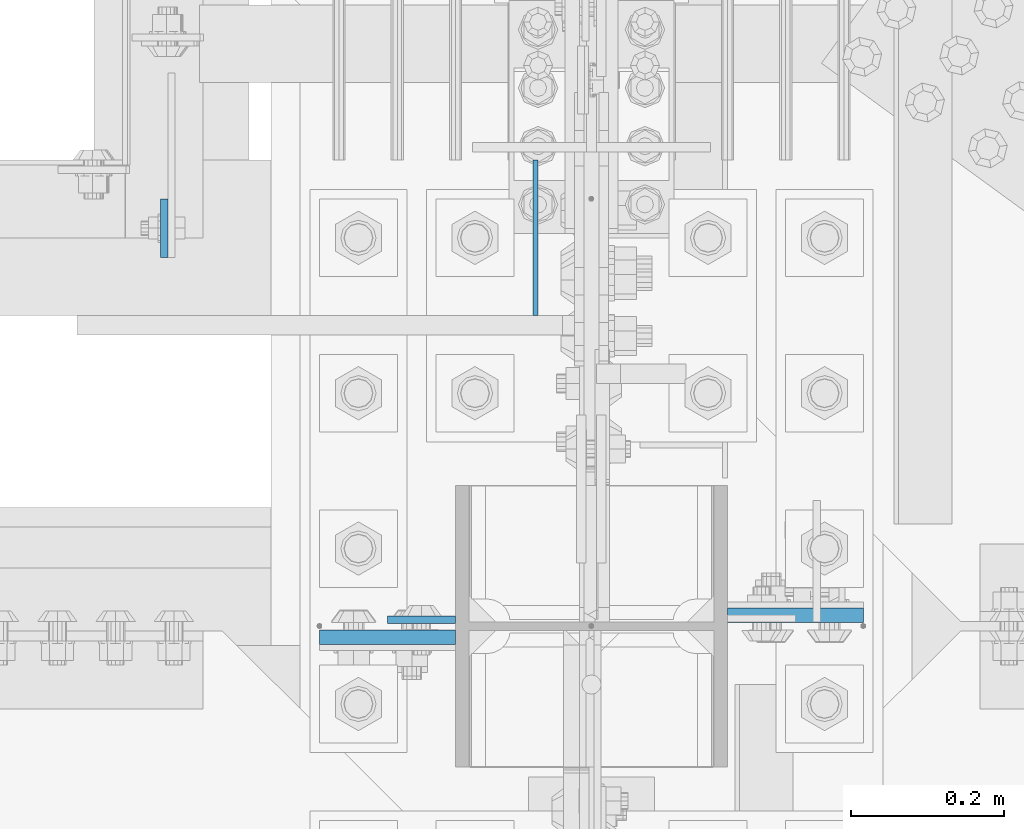
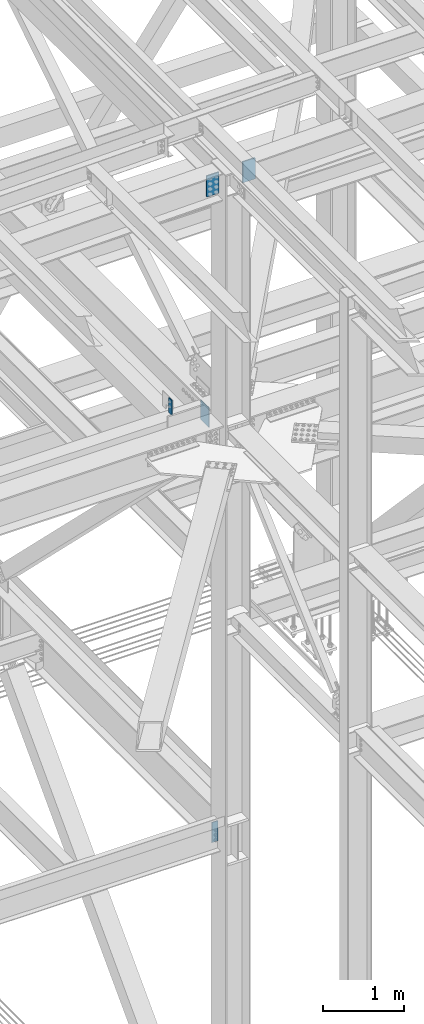
# One storey, part 1598 of 3843: 5 columns, 2 elements without a shape of their own.
"""IFC2X3 building model written with IfcOpenShell, lengths in millimetres."""

from ifc_helpers import new_model, si_unit, frame, origin_with_axes, place, context, subcontext, project, spatial, faceted_brep, material, type_object, element, aggregate, save


model = new_model("IFC2X3")

# Units and contexts
model_context = context("Model", 3, precision=1e-05, world=origin_with_axes())
body_context = subcontext(model_context, "Body", "Model", "MODEL_VIEW")
ifc_project = project(units=[si_unit("LENGTHUNIT", "METRE", prefix="MILLI"), si_unit("AREAUNIT", "SQUARE_METRE"), si_unit("VOLUMEUNIT", "CUBIC_METRE"), si_unit("MASSUNIT", "GRAM", prefix="KILO"), si_unit("TIMEUNIT", "SECOND"), si_unit("PLANEANGLEUNIT", "RADIAN"), si_unit("SOLIDANGLEUNIT", "STERADIAN"), si_unit("THERMODYNAMICTEMPERATUREUNIT", "DEGREE_CELSIUS"), si_unit("LUMINOUSINTENSITYUNIT", "LUMEN")], contexts=[model_context])

# Site, building, storey
site_placement = place(None, origin_with_axes())
site = spatial("IfcSite", under=ifc_project, at=site_placement, CompositionType="ELEMENT")
building_placement = place(site_placement, origin_with_axes())
building = spatial("IfcBuilding", under=site, at=building_placement, Name="Undefined", CompositionType="ELEMENT")
storey_placement = place(building_placement, origin_with_axes())
storey = spatial("IfcBuildingStorey", under=building, at=storey_placement, Name="Undefined", CompositionType="ELEMENT", Elevation=0.0)

# Assembly, columns
assembly_1_placement = place(storey_placement, origin_with_axes())
assembly_1 = element("IfcElementAssembly", 1, at=assembly_1_placement, inside=storey, Name="GIRT", AssemblyPlace="NOTDEFINED", PredefinedType="RIGID_FRAME")
ifc_material = material(Name="STEEL/A572-50")
column_type_1 = type_object("IfcColumnType", PredefinedType="NOTDEFINED")
column_1_placement = place(assembly_1_placement, frame((76939.775, 92722.7, 42062.4), z_axis=(0.0, 1.0, 0.0), x_axis=(0.0, 0.0, 1.0)))
column_1 = element("IfcColumn", 2, at=column_1_placement, type_object=column_type_1, material=ifc_material, Name="PLATE", context=body_context, shape_type="Brep", body=[
    faceted_brep([(0.0, 3.17499999999927, -101.600000000006), (0.0, 3.17499999999927, 101.600000000006), (304.800000000003, 3.17499999999927, 101.600000000006), (304.800000000003, 3.17499999999927, -101.600000000006), (0.0, -3.17499999999927, 101.600000000006), (304.800000000003, -3.17499999999927, 101.600000000006), (0.0, -3.17499999999927, -101.600000000006), (304.800000000003, -3.17499999999927, -101.600000000006)], [[[0, 1, 2, 3]], [[1, 4, 5, 2]], [[4, 6, 7, 5]], [[6, 0, 3, 7]], [[5, 7, 3, 2]], [[6, 4, 1, 0]]]),
])
column_type_2 = type_object("IfcColumnType", PredefinedType="NOTDEFINED")
column_2_placement = place(assembly_1_placement, frame((76454.0004821973, 92735.4005071216, 42367.2), z_axis=(0.0, 1.0, 0.0), x_axis=(0.0, 0.0, 1.0)))
column_2 = element("IfcColumn", 3, at=column_2_placement, type_object=column_type_2, material=ifc_material, Name="PLATE", context=body_context, shape_type="Brep", body=[
    faceted_brep([(0.0, 4.76250000000073, -38.0999999999985), (0.0, 4.76250000000073, 38.0999999999985), (228.599999999999, 4.76249999999709, 38.1000000000058), (228.599999999999, 4.76249999999709, -38.1000000000058), (0.0, -4.76250000000073, 38.0999999999985), (228.599999999999, -4.76249999999709, 38.1000000000058), (0.0, -4.76250000000073, -38.0999999999985), (228.599999999999, -4.76249999999709, -38.1000000000058)], [[[0, 1, 2, 3]], [[1, 4, 5, 2]], [[4, 6, 7, 5]], [[6, 0, 3, 7]], [[5, 7, 3, 2]], [[6, 4, 1, 0]]]),
])
aggregate(assembly_1, [column_1, column_2])

assembly_2_placement = place(storey_placement, origin_with_axes())
assembly_2 = element("IfcElementAssembly", 4, at=assembly_2_placement, inside=storey, Name="COLUMN", AssemblyPlace="NOTDEFINED", PredefinedType="RIGID_FRAME")
column_type_3 = type_object("IfcColumnType", PredefinedType="NOTDEFINED")
column_3_placement = place(assembly_2_placement, frame((77279.500000001, 92228.9875, 45916.910377094), z_axis=(-1.0, 0.0, 0.0), x_axis=(0.0, 0.0, 1.0)))
column_3 = element("IfcColumn", 5, at=column_3_placement, type_object=column_type_3, material=ifc_material, Name="PLATE", context=body_context, shape_type="Brep", body=[
    faceted_brep([(0.0, 9.52500000000146, -88.9000000000015), (0.0, 9.52500000000146, 88.9000000000015), (317.5, 9.52500000000146, 88.9000000000015), (317.5, 9.52500000000146, -88.9000000000015), (0.0, -9.52500000000146, 88.9000000000015), (317.5, -9.52500000000146, 88.9000000000015), (0.0, -9.52500000000146, -88.9000000000015), (317.5, -9.52500000000146, -88.9000000000015)], [[[0, 1, 2, 3]], [[1, 4, 5, 2]], [[4, 6, 7, 5]], [[6, 0, 3, 7]], [[5, 7, 3, 2]], [[6, 4, 1, 0]]]),
])
column_4_placement = place(assembly_2_placement, frame((76746.099999999, 92200.4125, 45906.9687789878), z_axis=(1.0, 0.0, 0.0), x_axis=(0.0, 0.0, 1.0)))
column_4 = element("IfcColumn", 6, at=column_4_placement, type_object=column_type_3, material=ifc_material, Name="PLATE", context=body_context, shape_type="Brep", body=[
    faceted_brep([(0.0, 9.52500000000146, -88.9000000000015), (0.0, 9.52500000000146, 88.9000000000015), (317.5, 9.52500000000146, 88.9000000000015), (317.5, 9.52500000000146, -88.9000000000015), (0.0, -9.52500000000146, 88.9000000000015), (317.5, -9.52500000000146, 88.9000000000015), (0.0, -9.52500000000146, -88.9000000000015), (317.5, -9.52500000000146, -88.9000000000015)], [[[0, 1, 2, 3]], [[1, 4, 5, 2]], [[4, 6, 7, 5]], [[6, 0, 3, 7]], [[5, 7, 3, 2]], [[6, 4, 1, 0]]]),
])
column_type_4 = type_object("IfcColumnType", PredefinedType="NOTDEFINED")
column_5_placement = place(assembly_2_placement, frame((76790.55, 92223.43125, 36093.4), z_axis=(1.0, 0.0, 0.0), x_axis=(0.0, 0.0, 1.0)))
column_5 = element("IfcColumn", 7, at=column_5_placement, type_object=column_type_4, material=ifc_material, Name="PLATE", context=body_context, shape_type="Brep", body=[
    faceted_brep([(0.0, 4.76249999999709, -44.4500000000007), (0.0, 4.76249999999709, 44.4500000000007), (304.799999999996, 4.76249999999709, 44.4500000000007), (304.799999999996, 4.76249999999709, -44.4500000000007), (0.0, -4.76249999999709, 44.4500000000007), (304.799999999996, -4.76249999999709, 44.4500000000007), (0.0, -4.76249999999709, -44.4500000000007), (304.799999999996, -4.76249999999709, -44.4500000000007)], [[[0, 1, 2, 3]], [[1, 4, 5, 2]], [[4, 6, 7, 5]], [[6, 0, 3, 7]], [[5, 7, 3, 2]], [[6, 4, 1, 0]]]),
])
aggregate(assembly_2, [column_3, column_4, column_5])

save(model, "model.ifc")
